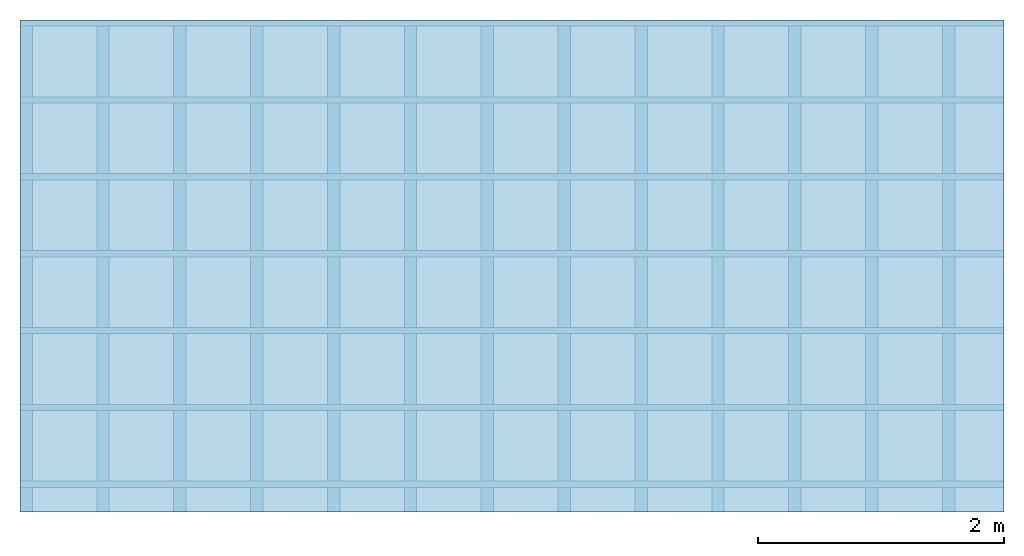
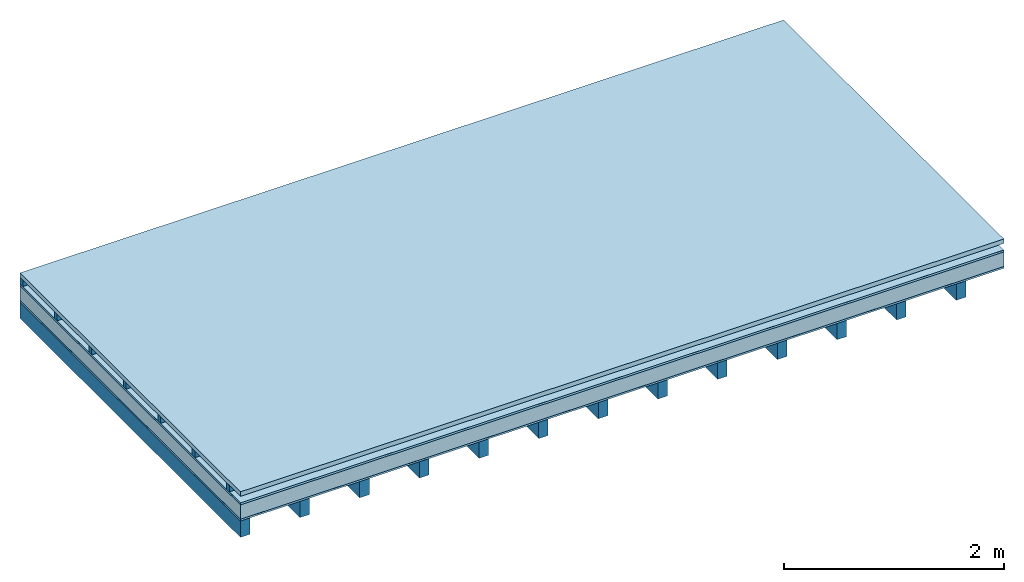
# One storey: 6 plates, 2 members, 1 element without a shape of its own.
"""IFC4 building model written with IfcOpenShell, lengths in metres."""

from ifc_helpers import new_model, si_unit, derived_unit, direction, frame, frame_2d, origin, origin_with_axes, place, context, project, spatial, rectangle, extrude, material, layer, layer_set, type_object, element, aggregate, save


model = new_model("IFC4")

# Units and contexts
plan_context = context("Plan", 3, precision=1e-05, world=origin(), true_north=direction((0.0, 1.0)))
model_context = context("Model", 3, precision=1e-05, world=origin(), true_north=direction((0.0, 1.0)))
ifc_project = project(units=[si_unit("LENGTHUNIT", "METRE"), derived_unit("SOUNDPRESSUREUNIT", [(si_unit("PRESSUREUNIT", "PASCAL", prefix="MICRO"), 0)]), si_unit("ENERGYUNIT", "JOULE", prefix="MEGA"), si_unit("MASSUNIT", "GRAM", prefix="KILO"), derived_unit("THERMALTRANSMITTANCEUNIT", [(si_unit("POWERUNIT", "WATT"), 1), (si_unit("AREAUNIT", "SQUARE_METRE"), -1), (si_unit("THERMODYNAMICTEMPERATUREUNIT", "KELVIN"), -1)]), derived_unit("AREADENSITYUNIT", [(si_unit("MASSUNIT", "GRAM", prefix="KILO"), 1), (si_unit("AREAUNIT", "SQUARE_METRE"), -1)]), derived_unit("USERDEFINED", [(si_unit("ENERGYUNIT", "JOULE", prefix="MEGA"), 1), (si_unit("AREAUNIT", "SQUARE_METRE"), -1)])], contexts=[plan_context, model_context])

# Site, building, storey
site = spatial("IfcSite", under=ifc_project)
building_placement = place(None, origin())
building = spatial("IfcBuilding", under=site, at=building_placement)
storey_placement = place(building_placement, origin())
storey = spatial("IfcBuildingStorey", under=building, at=storey_placement)

# Slab, members, plates
ifc_material_1 = material(Name="Roof tiles", Category="03.015")
ifc_layer_1 = layer(ifc_material_1, 0.05, Name="Roofing")
ifc_layer_2 = layer(None, 0.072, Name="Battens / profiles")
ifc_material_2 = material(Name="Roofing underlay", Category="09.008")
ifc_layer_3 = layer(ifc_material_2, 0.00018, Name="Under the roof")
ifc_material_3 = material(Category="10.009")
ifc_layer_4 = layer(ifc_material_3, 0.022, Name="Exterior insulation layer 2")
ifc_material_4 = material(Category="10.008")
ifc_layer_5 = layer(ifc_material_4, 0.16, Name="Exterior insulation layer 1")
ifc_material_5 = material(Name="Vapor barrier polyethylene (PE)", Category="09.002")
ifc_layer_6 = layer(ifc_material_5, 0.00018, Name="above 1st layer")
ifc_material_6 = material(Name="Boards with edges", Category="07.009")
ifc_layer_7 = layer(ifc_material_6, 0.02, Name="Sub-floor")
ifc_material_7 = material(Name="of the art")
ifc_layer_8 = layer(ifc_material_7, 0.0, Name="Bond")
ifc_layer_9 = layer(None, 0.18, Name="Supporting structure")
ifc_layer_set = layer_set([ifc_layer_1, ifc_layer_2, ifc_layer_3, ifc_layer_4, ifc_layer_5, ifc_layer_6, ifc_layer_7, ifc_layer_8, ifc_layer_9])
slab_type = type_object("IfcSlabType", Name="E0167", PredefinedType="NOTDEFINED", material=ifc_layer_set)
slab_placement = place(None, frame((0.0, 0.0, 0.0), z_axis=(0.0, 0.0, -1.0), x_axis=(1.0, 0.0, 0.0)))
slab = element("IfcSlab", 1, at=slab_placement, inside=storey, type_object=slab_type, material=ifc_layer_set, Name="Slab #1")
ifc_material_8 = material()
member_1_placement = place(slab_placement, origin())
member_1 = element("IfcMember", 2, at=member_1_placement, material=ifc_material_8, Name="Battens / profiles", context=plan_context, shape_type="SweptSolid", body=[
    extrude(rectangle(XDim=0.05, YDim=0.072, at=frame_2d((0.025, 0.036), x_axis=(1.0, 0.0))), frame((0.0, 0.0, 0.05), z_axis=(1.0, 0.0, 0.0), x_axis=(0.0, 1.0, 0.0)), (0.0, 0.0, 1.0), 8.0),
    extrude(rectangle(XDim=0.05, YDim=0.072, at=frame_2d((0.025, 0.036), x_axis=(1.0, 0.0))), frame((0.0, 0.625, 0.05), z_axis=(1.0, 0.0, 0.0), x_axis=(0.0, 1.0, 0.0)), (0.0, 0.0, 1.0), 8.0),
    extrude(rectangle(XDim=0.05, YDim=0.072, at=frame_2d((0.025, 0.036), x_axis=(1.0, 0.0))), frame((0.0, 1.25, 0.05), z_axis=(1.0, 0.0, 0.0), x_axis=(0.0, 1.0, 0.0)), (0.0, 0.0, 1.0), 8.0),
    extrude(rectangle(XDim=0.05, YDim=0.072, at=frame_2d((0.025, 0.036), x_axis=(1.0, 0.0))), frame((0.0, 1.875, 0.05), z_axis=(1.0, 0.0, 0.0), x_axis=(0.0, 1.0, 0.0)), (0.0, 0.0, 1.0), 8.0),
    extrude(rectangle(XDim=0.05, YDim=0.072, at=frame_2d((0.025, 0.036), x_axis=(1.0, 0.0))), frame((0.0, 2.5, 0.05), z_axis=(1.0, 0.0, 0.0), x_axis=(0.0, 1.0, 0.0)), (0.0, 0.0, 1.0), 8.0),
    extrude(rectangle(XDim=0.05, YDim=0.072, at=frame_2d((0.025, 0.036), x_axis=(1.0, 0.0))), frame((0.0, 3.125, 0.05), z_axis=(1.0, 0.0, 0.0), x_axis=(0.0, 1.0, 0.0)), (0.0, 0.0, 1.0), 8.0),
    extrude(rectangle(XDim=0.05, YDim=0.072, at=frame_2d((0.025, 0.036), x_axis=(1.0, 0.0))), frame((0.0, 3.75, 0.05), z_axis=(1.0, 0.0, 0.0), x_axis=(0.0, 1.0, 0.0)), (0.0, 0.0, 1.0), 8.0),
])
ifc_material_9 = material()
member_2_placement = place(slab_placement, origin())
member_2 = element("IfcMember", 3, at=member_2_placement, material=ifc_material_9, Name="Supporting structure", context=plan_context, shape_type="SweptSolid", body=[
    extrude(rectangle(XDim=0.1, YDim=0.18, at=frame_2d((0.05, 0.09), x_axis=(1.0, 0.0))), frame((0.0, 4.0, 0.32436), z_axis=(0.0, -1.0, 0.0), x_axis=(1.0, 0.0, 0.0)), (0.0, 0.0, 1.0), 4.0),
    extrude(rectangle(XDim=0.1, YDim=0.18, at=frame_2d((0.05, 0.09), x_axis=(1.0, 0.0))), frame((0.625, 4.0, 0.32436), z_axis=(0.0, -1.0, 0.0), x_axis=(1.0, 0.0, 0.0)), (0.0, 0.0, 1.0), 4.0),
    extrude(rectangle(XDim=0.1, YDim=0.18, at=frame_2d((0.05, 0.09), x_axis=(1.0, 0.0))), frame((1.25, 4.0, 0.32436), z_axis=(0.0, -1.0, 0.0), x_axis=(1.0, 0.0, 0.0)), (0.0, 0.0, 1.0), 4.0),
    extrude(rectangle(XDim=0.1, YDim=0.18, at=frame_2d((0.05, 0.09), x_axis=(1.0, 0.0))), frame((1.875, 4.0, 0.32436), z_axis=(0.0, -1.0, 0.0), x_axis=(1.0, 0.0, 0.0)), (0.0, 0.0, 1.0), 4.0),
    extrude(rectangle(XDim=0.1, YDim=0.18, at=frame_2d((0.05, 0.09), x_axis=(1.0, 0.0))), frame((2.5, 4.0, 0.32436), z_axis=(0.0, -1.0, 0.0), x_axis=(1.0, 0.0, 0.0)), (0.0, 0.0, 1.0), 4.0),
    extrude(rectangle(XDim=0.1, YDim=0.18, at=frame_2d((0.05, 0.09), x_axis=(1.0, 0.0))), frame((3.125, 4.0, 0.32436), z_axis=(0.0, -1.0, 0.0), x_axis=(1.0, 0.0, 0.0)), (0.0, 0.0, 1.0), 4.0),
    extrude(rectangle(XDim=0.1, YDim=0.18, at=frame_2d((0.05, 0.09), x_axis=(1.0, 0.0))), frame((3.75, 4.0, 0.32436), z_axis=(0.0, -1.0, 0.0), x_axis=(1.0, 0.0, 0.0)), (0.0, 0.0, 1.0), 4.0),
    extrude(rectangle(XDim=0.1, YDim=0.18, at=frame_2d((0.05, 0.09), x_axis=(1.0, 0.0))), frame((4.375, 4.0, 0.32436), z_axis=(0.0, -1.0, 0.0), x_axis=(1.0, 0.0, 0.0)), (0.0, 0.0, 1.0), 4.0),
    extrude(rectangle(XDim=0.1, YDim=0.18, at=frame_2d((0.05, 0.09), x_axis=(1.0, 0.0))), frame((5.0, 4.0, 0.32436), z_axis=(0.0, -1.0, 0.0), x_axis=(1.0, 0.0, 0.0)), (0.0, 0.0, 1.0), 4.0),
    extrude(rectangle(XDim=0.1, YDim=0.18, at=frame_2d((0.05, 0.09), x_axis=(1.0, 0.0))), frame((5.625, 4.0, 0.32436), z_axis=(0.0, -1.0, 0.0), x_axis=(1.0, 0.0, 0.0)), (0.0, 0.0, 1.0), 4.0),
    extrude(rectangle(XDim=0.1, YDim=0.18, at=frame_2d((0.05, 0.09), x_axis=(1.0, 0.0))), frame((6.25, 4.0, 0.32436), z_axis=(0.0, -1.0, 0.0), x_axis=(1.0, 0.0, 0.0)), (0.0, 0.0, 1.0), 4.0),
    extrude(rectangle(XDim=0.1, YDim=0.18, at=frame_2d((0.05, 0.09), x_axis=(1.0, 0.0))), frame((6.875, 4.0, 0.32436), z_axis=(0.0, -1.0, 0.0), x_axis=(1.0, 0.0, 0.0)), (0.0, 0.0, 1.0), 4.0),
    extrude(rectangle(XDim=0.1, YDim=0.18, at=frame_2d((0.05, 0.09), x_axis=(1.0, 0.0))), frame((7.5, 4.0, 0.32436), z_axis=(0.0, -1.0, 0.0), x_axis=(1.0, 0.0, 0.0)), (0.0, 0.0, 1.0), 4.0),
])
plate_1_placement = place(slab_placement, origin())
plate_1 = element("IfcPlate", 4, at=plate_1_placement, material=ifc_material_1, Name="Roofing", context=plan_context, shape_type="SweptSolid", body=[
    extrude(rectangle(XDim=8.0, YDim=4.0, at=frame_2d((4.0, 2.0), x_axis=(1.0, 0.0))), origin_with_axes(), (0.0, 0.0, 1.0), 0.05),
])
plate_2_placement = place(slab_placement, origin())
plate_2 = element("IfcPlate", 5, at=plate_2_placement, material=ifc_material_2, Name="Under the roof", context=plan_context, shape_type="SweptSolid", body=[
    extrude(rectangle(XDim=8.0, YDim=4.0, at=frame_2d((4.0, 2.0), x_axis=(1.0, 0.0))), frame((0.0, 0.0, 0.122), z_axis=(0.0, 0.0, 1.0), x_axis=(1.0, 0.0, 0.0)), (0.0, 0.0, 1.0), 0.00018),
])
plate_3_placement = place(slab_placement, origin())
plate_3 = element("IfcPlate", 6, at=plate_3_placement, material=ifc_material_3, Name="Exterior insulation layer 2", context=plan_context, shape_type="SweptSolid", body=[
    extrude(rectangle(XDim=8.0, YDim=4.0, at=frame_2d((4.0, 2.0), x_axis=(1.0, 0.0))), frame((0.0, 0.0, 0.12218), z_axis=(0.0, 0.0, 1.0), x_axis=(1.0, 0.0, 0.0)), (0.0, 0.0, 1.0), 0.022),
])
plate_4_placement = place(slab_placement, origin())
plate_4 = element("IfcPlate", 7, at=plate_4_placement, material=ifc_material_4, Name="Exterior insulation layer 1", context=plan_context, shape_type="SweptSolid", body=[
    extrude(rectangle(XDim=8.0, YDim=4.0, at=frame_2d((4.0, 2.0), x_axis=(1.0, 0.0))), frame((0.0, 0.0, 0.14418), z_axis=(0.0, 0.0, 1.0), x_axis=(1.0, 0.0, 0.0)), (0.0, 0.0, 1.0), 0.16),
])
plate_5_placement = place(slab_placement, origin())
plate_5 = element("IfcPlate", 8, at=plate_5_placement, material=ifc_material_5, Name="above 1st layer", context=plan_context, shape_type="SweptSolid", body=[
    extrude(rectangle(XDim=8.0, YDim=4.0, at=frame_2d((4.0, 2.0), x_axis=(1.0, 0.0))), frame((0.0, 0.0, 0.30418), z_axis=(0.0, 0.0, 1.0), x_axis=(1.0, 0.0, 0.0)), (0.0, 0.0, 1.0), 0.00018),
])
plate_6_placement = place(slab_placement, origin())
plate_6 = element("IfcPlate", 9, at=plate_6_placement, material=ifc_material_6, Name="Sub-floor", context=plan_context, shape_type="SweptSolid", body=[
    extrude(rectangle(XDim=8.0, YDim=4.0, at=frame_2d((4.0, 2.0), x_axis=(1.0, 0.0))), frame((0.0, 0.0, 0.30436), z_axis=(0.0, 0.0, 1.0), x_axis=(1.0, 0.0, 0.0)), (0.0, 0.0, 1.0), 0.02),
])
aggregate(slab, [plate_1, member_1, plate_2, plate_3, plate_4, plate_5, plate_6, member_2])

save(model, "model.ifc")
